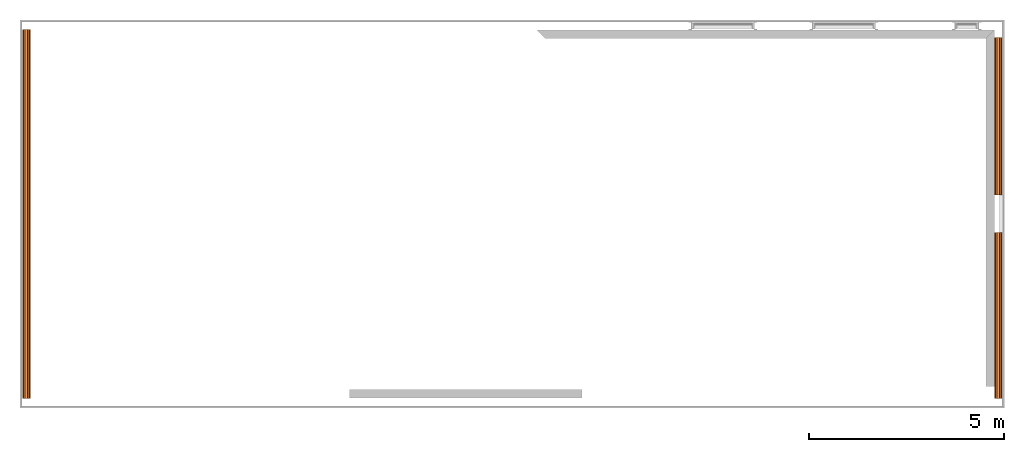
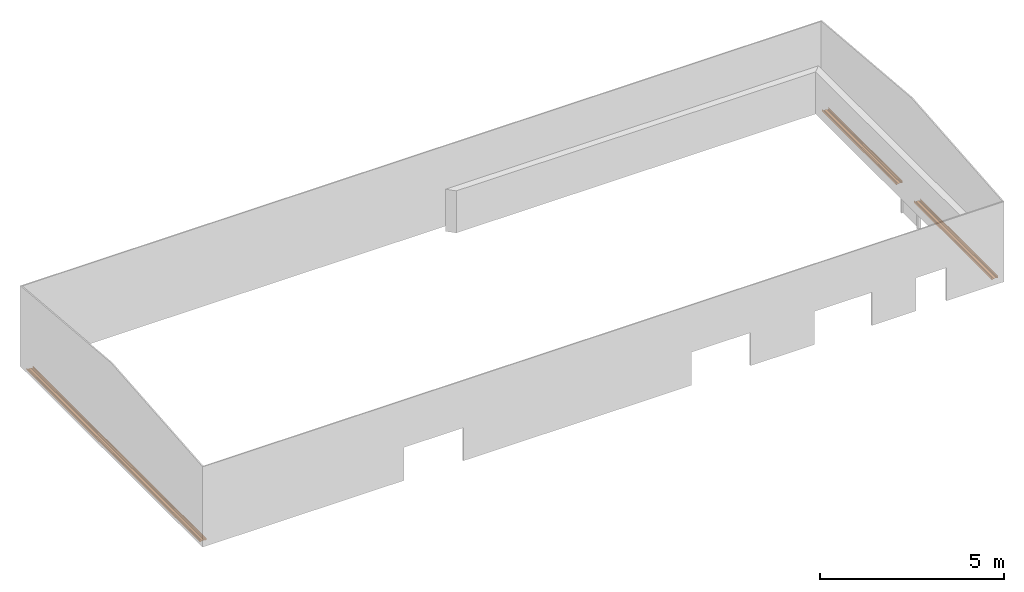
# One storey, part 4 of 4: 3 proxies.
"""IFC2X3 building model written with IfcOpenShell, lengths in millimetres."""

import ifcopenshell
import ifcopenshell.guid

model = None  # the IFC model being written
_history = None  # IfcOwnerHistory: only IFC2X3 demands one
_inside = {}  # id of a spatial element -> (the spatial element, [elements in it])
_under = {}  # id of a project, library or spatial element -> (it, [spatial elements below it])
_declared = {}  # id of a project -> (the project, [libraries it declares])
_typed = {}  # id of a type object -> (the type object, [elements of that type])
_made_of = {}  # id of a material, layer set ... -> (it, [elements and type objects made of it])


def new_model(schema):
    """Start an empty IFC model of exactly this schema.

    Asked for "IFC4X3", IfcOpenShell would pick the latest addendum, in which some entities
    have other attributes; the version numbers below select the first issue.
    IFC2X3 requires an IfcOwnerHistory on every rooted entity: one is made here for all.
    """
    global model, _history
    if schema == "IFC4X3":
        model = ifcopenshell.file(schema_version=(4, 3, 0, 0))
    else:
        model = ifcopenshell.file(schema=schema)
    _inside.clear()
    _under.clear()
    _declared.clear()
    _typed.clear()
    _made_of.clear()
    _history = None
    if model.schema == "IFC2X3":
        org = make("IfcOrganization", Name="unknown")
        user = make(
            "IfcPersonAndOrganization",
            ThePerson=make("IfcPerson", FamilyName="unknown"),
            TheOrganization=org,
        )
        app = make(
            "IfcApplication",
            ApplicationDeveloper=org,
            Version="unknown",
            ApplicationFullName="unknown",
            ApplicationIdentifier="unknown",
        )
        _history = make(
            "IfcOwnerHistory",
            OwningUser=user,
            OwningApplication=app,
            ChangeAction="ADDED",
            CreationDate=0,
        )
    return model


def make(cls, **values):
    """One entity of the class cls with the attributes given. An attribute that is None is left unset."""
    return model.create_entity(
        cls, **{name: value for name, value in values.items() if value is not None}
    )


def entity(cls, *values):
    """Any entity or typed value of the class cls, its attributes in the order of the schema. None: left unset."""
    e = model.create_entity(cls)
    for i, value in enumerate(values):
        if value is not None:
            e[i] = value
    return e


def rooted(cls, **values):
    """An entity with a GlobalId (a new one), such as an element, a storey or a relation."""
    return make(cls, GlobalId=ifcopenshell.guid.new(), OwnerHistory=_history, **values)


def si_unit(unit_type, name, prefix=None):
    """IfcSIUnit, for example si_unit("LENGTHUNIT", "METRE", prefix="MILLI")."""
    return make("IfcSIUnit", UnitType=unit_type, Prefix=prefix, Name=name)


def converted_unit(unit_type, name, factor, base, dimensions=None, offset=None):
    """IfcConversionBasedUnit, such as the inch: factor (a typed value) times the base unit."""
    return make(
        "IfcConversionBasedUnit"
        if offset is None
        else "IfcConversionBasedUnitWithOffset",
        ConversionOffset=offset,
        Dimensions=None
        if dimensions is None
        else entity("IfcDimensionalExponents", *dimensions),
        UnitType=unit_type,
        Name=name,
        ConversionFactor=make(
            "IfcMeasureWithUnit", ValueComponent=factor, UnitComponent=base
        ),
    )


def money_unit(currency):
    """IfcMonetaryUnit."""
    return make("IfcMonetaryUnit", Currency=currency)


def assignment(units):
    """IfcUnitAssignment: the units of a project."""
    return None if units is None else make("IfcUnitAssignment", Units=units)


def point(xyz):
    """IfcCartesianPoint."""
    return None if xyz is None else make("IfcCartesianPoint", Coordinates=xyz)


def direction(xyz):
    """IfcDirection."""
    return None if xyz is None else make("IfcDirection", DirectionRatios=xyz)


def frame(location, z_axis=None, x_axis=None):
    """IfcAxis2Placement3D, a coordinate frame: its origin and axes. An axis left out is left unset."""
    return make(
        "IfcAxis2Placement3D",
        Location=point(location),
        Axis=direction(z_axis),
        RefDirection=direction(x_axis),
    )


def origin_with_axes():
    """The frame at (0, 0, 0) with the z axis (0, 0, 1) and the x axis (1, 0, 0) written out."""
    return frame((0.0, 0.0, 0.0), z_axis=(0.0, 0.0, 1.0), x_axis=(1.0, 0.0, 0.0))


def place(relative_to, where):
    """IfcLocalPlacement: puts the frame where relative to a parent placement (None: the world)."""
    return make(
        "IfcLocalPlacement", PlacementRelTo=relative_to, RelativePlacement=where
    )


def context(
    kind, dimensions, precision=None, world=None, true_north=None, identifier=None
):
    """IfcGeometricRepresentationContext, for example the 3D "Model" context."""
    return make(
        "IfcGeometricRepresentationContext",
        ContextIdentifier=identifier,
        ContextType=kind,
        CoordinateSpaceDimension=dimensions,
        Precision=precision,
        WorldCoordinateSystem=world,
        TrueNorth=true_north,
    )


def subcontext(parent, identifier, kind, view, scale=None):
    """IfcGeometricRepresentationSubContext, for example "Body" below "Model"."""
    return make(
        "IfcGeometricRepresentationSubContext",
        ContextIdentifier=identifier,
        ContextType=kind,
        ParentContext=parent,
        TargetScale=scale,
        TargetView=view,
    )


def project(units=None, contexts=None):
    """IfcProject with its units and contexts."""
    return rooted(
        "IfcProject",
        Name="project",
        RepresentationContexts=contexts,
        UnitsInContext=assignment(units),
    )


def spatial(cls, under=None, at=None, **own):
    """A site, building, storey or space (cls), placed at a placement, below another one or the project."""
    s = rooted(cls, ObjectPlacement=at, **own)
    if under is not None:
        _under.setdefault(under.id(), (under, []))[1].append(s)
    return s


def faces_of(points, faces, orient=None, outer=None):
    """IfcFace entities. A face is a list of loops; a loop is a list of indices into points, from 0.

    orient and outer hold one flag for each loop. By default every Orientation is true, the
    first loop of a face is its IfcFaceOuterBound and the others are IfcFaceBound.
    """
    made = []
    for i, loops in enumerate(faces):
        bounds = []
        for j, loop in enumerate(loops):
            is_outer = j == 0 if outer is None else outer[i][j]
            bounds.append(
                make(
                    "IfcFaceOuterBound" if is_outer else "IfcFaceBound",
                    Bound=make("IfcPolyLoop", Polygon=[points[k] for k in loop]),
                    Orientation=True if orient is None else orient[i][j],
                )
            )
        made.append(make("IfcFace", Bounds=bounds))
    return made


def faceted_brep(points, faces, orient=None, outer=None, voids=None):
    """IfcFacetedBrep: a solid bounded by flat faces; with voids (closed shells), ...WithVoids."""
    shared = [point(p) for p in points]
    hull = make("IfcClosedShell", CfsFaces=faces_of(shared, faces, orient, outer))
    if voids is None:
        return make("IfcFacetedBrep", Outer=hull)
    return make(
        "IfcFacetedBrepWithVoids",
        Outer=hull,
        Voids=[
            make(cls, CfsFaces=faces_of(shared, fs, o, b)) for cls, fs, o, b in voids
        ],
    )


def shape(context_of_items, identifier, shape_type, items):
    """IfcShapeRepresentation: the items that make up one representation, for example the "Body"."""
    return make(
        "IfcShapeRepresentation",
        ContextOfItems=context_of_items,
        RepresentationIdentifier=identifier,
        RepresentationType=shape_type,
        Items=items,
    )


def material(Name=None, Category=None):
    """IfcMaterial."""
    return make("IfcMaterial", Name=Name, Category=Category)


def made_of(thing, what):
    """Note that an element or type object is made of a material, layer set ...; save() writes the relation."""
    if what is not None:
        _made_of.setdefault(what.id(), (what, []))[1].append(thing)
    return thing


def type_object(cls, material=None, **own):
    """A type object (cls), such as IfcWallType, which elements share."""
    return made_of(rooted(cls, **own), material)


def element(
    cls,
    number,
    at=None,
    inside=None,
    cuts=None,
    type_object=None,
    material=None,
    context=None,
    identifier="Body",
    shape_type=None,
    held_by="IfcProductDefinitionShape",
    body=None,
    shapes=None,
    **own,
):
    """One element of the class cls, such as IfcWall. Its Tag is "e" and its number.

    at: its placement. inside: the storey or other place that contains it. cuts: it is an
    opening in that element (IfcRelVoidsElement). A single representation is given by context,
    identifier, shape_type and body (its items); several are given by shapes. held_by: the class
    of the entity that holds the representations. save() writes the other relations.
    """
    e = rooted(cls, Tag="e%d" % number, ObjectPlacement=at, **own)
    if body is not None:
        shapes = [shape(context, identifier, shape_type, body)]
    if shapes is not None:
        e.Representation = make(held_by, Representations=shapes)
    if inside is not None:
        _inside.setdefault(inside.id(), (inside, []))[1].append(e)
    if cuts is not None:
        rooted(
            "IfcRelVoidsElement", RelatingBuildingElement=cuts, RelatedOpeningElement=e
        )
    if type_object is not None:
        _typed.setdefault(type_object.id(), (type_object, []))[1].append(e)
    return made_of(e, material)


def aggregate(whole, parts):
    """IfcRelAggregates: a whole, such as a stair, and the parts it consists of."""
    return rooted("IfcRelAggregates", RelatingObject=whole, RelatedObjects=parts)


def save(model, path):
    """Write the relations noted so far, then the file.

    IfcRelAggregates (storeys below a building ...), IfcRelContainedInSpatialStructure (elements
    in a storey), IfcRelDefinesByType, IfcRelAssociatesMaterial and IfcRelDeclares: one each for
    every whole, place, type object, material and project.
    """
    for whole, parts in _under.values():
        aggregate(whole, parts)
    for where, things in _inside.values():
        rooted(
            "IfcRelContainedInSpatialStructure",
            RelatedElements=things,
            RelatingStructure=where,
        )
    for kind, things in _typed.values():
        rooted("IfcRelDefinesByType", RelatedObjects=things, RelatingType=kind)
    for what, things in _made_of.values():
        rooted("IfcRelAssociatesMaterial", RelatedObjects=things, RelatingMaterial=what)
    for by, libraries in _declared.values():
        rooted("IfcRelDeclares", RelatingContext=by, RelatedDefinitions=libraries)
    model.write(path)


model = new_model("IFC2X3")

# Units and contexts
model_context = context("Model", 3, precision=1e-05, world=origin_with_axes(), true_north=direction((0.0, 1.0)))
body_context = subcontext(model_context, "Body", "Model", "MODEL_VIEW")
ifc_project = project(units=[si_unit("LENGTHUNIT", "METRE", prefix="MILLI"), si_unit("AREAUNIT", "SQUARE_METRE"), si_unit("VOLUMEUNIT", "CUBIC_METRE"), converted_unit("PLANEANGLEUNIT", "DEGREE", entity("IfcPlaneAngleMeasure", 0.0174532925199), si_unit("PLANEANGLEUNIT", "RADIAN"), dimensions=[0, 0, 0, 0, 0, 0, 0]), si_unit("SOLIDANGLEUNIT", "STERADIAN"), money_unit("USD"), converted_unit("TIMEUNIT", "Year", entity("IfcTimeMeasure", 31556926.0), si_unit("TIMEUNIT", "SECOND"), dimensions=[0, 0, 0, 0, 0, 0, 0]), si_unit("MASSUNIT", "GRAM"), si_unit("THERMODYNAMICTEMPERATUREUNIT", "DEGREE_CELSIUS"), si_unit("LUMINOUSINTENSITYUNIT", "LUMEN")], contexts=[model_context])

# Site, building, storey
site_placement = place(None, origin_with_axes())
site = spatial("IfcSite", under=ifc_project, at=site_placement, CompositionType="ELEMENT")
building_placement = place(site_placement, origin_with_axes())
building = spatial("IfcBuilding", under=site, at=building_placement, CompositionType="ELEMENT")
storey_placement = place(building_placement, frame((0.0, 0.0, 71700.0), z_axis=(0.0, 0.0, 1.0), x_axis=(1.0, 0.0, 0.0)))
storey = spatial("IfcBuildingStorey", under=building, at=storey_placement, CompositionType="ELEMENT", Elevation=71700.0)

# Proxies
ifc_material_1 = material(Name="Metal - Steel - Light Gauge")
building_element_proxy_type_1 = type_object("IfcBuildingElementProxyType", Name="M", PredefinedType="USERDEFINED")
proxy_1_placement = place(storey_placement, frame((16615.5295383, 1237.47930537, 0.0), z_axis=(0.0, 0.0, 1.0), x_axis=(0.0, -1.0, 0.0)))
element("IfcBuildingElementProxy", 1, at=proxy_1_placement, inside=storey, type_object=building_element_proxy_type_1, material=ifc_material_1, Name="Light Gauge-Kingspan Rails:M", ObjectType="M", context=body_context, shape_type="Brep", body=[
    faceted_brep([(-1860.0014251, 70.5, 0.0), (-1860.0014251, 99.3, 0.0), (2385.5, 99.3, 0.0), (2385.5, 70.5, 0.0), (-1860.0014251, 32.5, 20.0), (-1860.0014251, -32.5, 20.0), (-1860.0014251, -70.5, 0.0), (-1860.0014251, -99.3, 0.0), (-1860.0014251, -100.524586984, 0.24358549596), (-1860.0014251, -101.5627417, 0.9372583002), (-1860.0014251, -102.256414504, 1.97541301643), (-1860.0014251, -102.5, 3.2), (-1860.0014251, -102.5, 61.8), (-1860.0014251, -102.256414504, 63.0245869836), (-1860.0014251, -101.5627417, 64.0627416998), (-1860.0014251, -100.524586984, 64.756414504), (-1860.0014251, -99.3, 65.0), (-1860.0014251, -91.7, 65.0), (-1860.0014251, -90.4754130164, 64.756414504), (-1860.0014251, -89.4372583002, 64.0627416998), (-1860.0014251, -88.743585496, 63.0245869836), (-1860.0014251, -88.5, 61.8), (-1860.0014251, -88.5, 53.0), (-1860.0014251, -90.1, 53.0), (-1860.0014251, -90.1, 61.8), (-1860.0014251, -90.221792748, 62.4122934918), (-1860.0014251, -90.5686291501, 62.9313708499), (-1860.0014251, -91.0877065082, 63.278207252), (-1860.0014251, -91.7, 63.4), (-1860.0014251, -99.3, 63.4), (-1860.0014251, -99.9122934918, 63.278207252), (-1860.0014251, -100.43137085, 62.9313708499), (-1860.0014251, -100.778207252, 62.4122934918), (-1860.0014251, -100.9, 61.8), (-1860.0014251, -100.9, 3.2), (-1860.0014251, -100.778207252, 2.58770650822), (-1860.0014251, -100.43137085, 2.0686291501), (-1860.0014251, -99.9122934918, 1.72179274798), (-1860.0014251, -99.3, 1.6), (-1860.0014251, -70.8953456886, 1.6), (-1860.0014251, -32.8953456886, 21.6), (-1860.0014251, 32.8953456886, 21.6), (-1860.0014251, 70.8953456886, 1.6), (-1860.0014251, 99.3, 1.6), (-1860.0014251, 99.9122934918, 1.72179274798), (-1860.0014251, 100.43137085, 2.0686291501), (-1860.0014251, 100.778207252, 2.58770650822), (-1860.0014251, 100.9, 3.2), (-1860.0014251, 100.9, 61.8), (-1860.0014251, 100.778207252, 62.4122934918), (-1860.0014251, 100.43137085, 62.9313708499), (-1860.0014251, 99.9122934918, 63.278207252), (-1860.0014251, 99.3, 63.4), (-1860.0014251, 91.7, 63.4), (-1860.0014251, 91.0877065082, 63.278207252), (-1860.0014251, 90.5686291501, 62.9313708499), (-1860.0014251, 90.221792748, 62.4122934918), (-1860.0014251, 90.1, 61.8), (-1860.0014251, 90.1, 53.0), (-1860.0014251, 88.5, 53.0), (-1860.0014251, 88.5, 61.8), (-1860.0014251, 88.743585496, 63.0245869836), (-1860.0014251, 89.4372583002, 64.0627416998), (-1860.0014251, 90.4754130164, 64.756414504), (-1860.0014251, 91.7, 65.0), (-1860.0014251, 99.3, 65.0), (-1860.0014251, 100.524586984, 64.756414504), (-1860.0014251, 101.5627417, 64.0627416998), (-1860.0014251, 102.256414504, 63.0245869836), (-1860.0014251, 102.5, 61.8), (-1860.0014251, 102.5, 3.2), (-1860.0014251, 102.256414504, 1.97541301643), (-1860.0014251, 101.5627417, 0.9372583002), (-1860.0014251, 100.524586984, 0.24358549596), (2385.5, 100.524586984, 0.24358549596), (2385.5, 101.5627417, 0.9372583002), (2385.5, 102.256414504, 1.97541301643), (2385.5, 102.5, 3.2), (2385.5, 102.5, 61.8), (2385.5, 102.256414504, 63.0245869836), (2385.5, 101.5627417, 64.0627416998), (2385.5, 100.524586984, 64.756414504), (2385.5, 99.3, 65.0), (2385.5, 91.7, 65.0), (2385.5, 90.4754130164, 64.756414504), (2385.5, 89.4372583002, 64.0627416998), (2385.5, 88.743585496, 63.0245869836), (2385.5, 88.5, 61.8), (2385.5, 88.5, 53.0), (2385.5, 90.1, 53.0), (2385.5, 90.1, 61.8), (2385.5, 90.221792748, 62.4122934918), (2385.5, 90.5686291501, 62.9313708499), (2385.5, 91.0877065082, 63.278207252), (2385.5, 91.7, 63.4), (2385.5, 99.3, 63.4), (2385.5, 99.9122934918, 63.278207252), (2385.5, 100.43137085, 62.9313708499), (2385.5, 100.778207252, 62.4122934918), (2385.5, 100.9, 61.8), (2385.5, 100.9, 3.2), (2385.5, 100.778207252, 2.58770650822), (2385.5, 100.43137085, 2.0686291501), (2385.5, 99.9122934918, 1.72179274798), (2385.5, 99.3, 1.6), (2385.5, 70.8953456886, 1.6), (2385.5, 32.8953456886, 21.6), (2385.5, -32.8953456886, 21.6), (2385.5, -70.8953456886, 1.6), (2385.5, -99.3, 1.6), (2385.5, -99.9122934918, 1.72179274798), (2385.5, -100.43137085, 2.0686291501), (2385.5, -100.778207252, 2.58770650822), (2385.5, -100.9, 3.2), (2385.5, -100.9, 61.8), (2385.5, -100.778207252, 62.4122934918), (2385.5, -100.43137085, 62.9313708499), (2385.5, -99.9122934918, 63.278207252), (2385.5, -99.3, 63.4), (2385.5, -91.7, 63.4), (2385.5, -91.0877065082, 63.278207252), (2385.5, -90.5686291501, 62.9313708499), (2385.5, -90.221792748, 62.4122934918), (2385.5, -90.1, 61.8), (2385.5, -90.1, 53.0), (2385.5, -88.5, 53.0), (2385.5, -88.5, 61.8), (2385.5, -88.743585496, 63.0245869836), (2385.5, -89.4372583002, 64.0627416998), (2385.5, -90.4754130164, 64.756414504), (2385.5, -91.7, 65.0), (2385.5, -99.3, 65.0), (2385.5, -100.524586984, 64.756414504), (2385.5, -101.5627417, 64.0627416998), (2385.5, -102.256414504, 63.0245869836), (2385.5, -102.5, 61.8), (2385.5, -102.5, 3.2), (2385.5, -102.256414504, 1.97541301643), (2385.5, -101.5627417, 0.9372583002), (2385.5, -100.524586984, 0.24358549596), (2385.5, -99.3, 0.0), (2385.5, -70.5, 0.0), (2385.5, -32.5, 20.0), (2385.5, 32.5, 20.0)], [[[0, 1, 2, 3]], [[0, 4, 5, 6, 7, 8, 9, 10, 11, 12, 13, 14, 15, 16, 17, 18, 19, 20, 21, 22, 23, 24, 25, 26, 27, 28, 29, 30, 31, 32, 33, 34, 35, 36, 37, 38, 39, 40, 41, 42, 43, 44, 45, 46, 47, 48, 49, 50, 51, 52, 53, 54, 55, 56, 57, 58, 59, 60, 61, 62, 63, 64, 65, 66, 67, 68, 69, 70, 71, 72, 73, 1]], [[1, 73, 74, 2]], [[3, 2, 74, 75, 76, 77, 78, 79, 80, 81, 82, 83, 84, 85, 86, 87, 88, 89, 90, 91, 92, 93, 94, 95, 96, 97, 98, 99, 100, 101, 102, 103, 104, 105, 106, 107, 108, 109, 110, 111, 112, 113, 114, 115, 116, 117, 118, 119, 120, 121, 122, 123, 124, 125, 126, 127, 128, 129, 130, 131, 132, 133, 134, 135, 136, 137, 138, 139, 140, 141, 142, 143]], [[4, 0, 3, 143]], [[5, 4, 143, 142]], [[6, 5, 142, 141]], [[7, 6, 141, 140]], [[8, 7, 140, 139]], [[9, 8, 139, 138]], [[10, 9, 138, 137]], [[11, 10, 137, 136]], [[12, 11, 136, 135]], [[13, 12, 135, 134]], [[14, 13, 134, 133]], [[15, 14, 133, 132]], [[16, 15, 132, 131]], [[17, 16, 131, 130]], [[18, 17, 130, 129]], [[19, 18, 129, 128]], [[20, 19, 128, 127]], [[21, 20, 127, 126]], [[22, 21, 126, 125]], [[23, 22, 125, 124]], [[24, 23, 124, 123]], [[25, 24, 123, 122]], [[26, 25, 122, 121]], [[27, 26, 121, 120]], [[28, 27, 120, 119]], [[29, 28, 119, 118]], [[30, 29, 118, 117]], [[31, 30, 117, 116]], [[32, 31, 116, 115]], [[33, 32, 115, 114]], [[34, 33, 114, 113]], [[35, 34, 113, 112]], [[36, 35, 112, 111]], [[37, 36, 111, 110]], [[38, 37, 110, 109]], [[39, 38, 109, 108]], [[40, 39, 108, 107]], [[41, 40, 107, 106]], [[42, 41, 106, 105]], [[43, 42, 105, 104]], [[44, 43, 104, 103]], [[45, 44, 103, 102]], [[46, 45, 102, 101]], [[47, 46, 101, 100]], [[48, 47, 100, 99]], [[49, 48, 99, 98]], [[50, 49, 98, 97]], [[51, 50, 97, 96]], [[52, 51, 96, 95]], [[53, 52, 95, 94]], [[54, 53, 94, 93]], [[55, 54, 93, 92]], [[56, 55, 92, 91]], [[57, 56, 91, 90]], [[58, 57, 90, 89]], [[59, 58, 89, 88]], [[60, 59, 88, 87]], [[61, 60, 87, 86]], [[62, 61, 86, 85]], [[63, 62, 85, 84]], [[64, 63, 84, 83]], [[65, 64, 83, 82]], [[66, 65, 82, 81]], [[67, 66, 81, 80]], [[68, 67, 80, 79]], [[69, 68, 79, 78]], [[70, 69, 78, 77]], [[71, 70, 77, 76]], [[72, 71, 76, 75]], [[73, 72, 75, 74]]]),
])
ifc_material_2 = material(Name="Metal - Steel 43-275")
building_element_proxy_type_2 = type_object("IfcBuildingElementProxyType", Name="M", PredefinedType="USERDEFINED")
proxy_2_placement = place(storey_placement, frame((16615.5295383, 5944.98053801, 0.0), z_axis=(0.0, 0.0, 1.0), x_axis=(0.0, -1.0, 0.0)))
element("IfcBuildingElementProxy", 2, at=proxy_2_placement, inside=storey, type_object=building_element_proxy_type_2, material=ifc_material_2, Name="Light Gauge-Kingspan Rails:M", ObjectType="M", context=body_context, shape_type="Brep", body=[
    faceted_brep([(-2154.0, 70.5, 0.0), (-2154.0, 99.3, 0.0), (1887.0, 99.3, 0.0), (1887.0, 70.5, 0.0), (-2154.0, 32.5, 20.0), (-2154.0, -32.5, 20.0), (-2154.0, -70.5, 0.0), (-2154.0, -99.3, 0.0), (-2154.0, -100.524586984, 0.24358549596), (-2154.0, -101.5627417, 0.9372583002), (-2154.0, -102.256414504, 1.97541301643), (-2154.0, -102.5, 3.2), (-2154.0, -102.5, 61.8), (-2154.0, -102.256414504, 63.0245869836), (-2154.0, -101.5627417, 64.0627416998), (-2154.0, -100.524586984, 64.756414504), (-2154.0, -99.3, 65.0), (-2154.0, -91.7, 65.0), (-2154.0, -90.4754130164, 64.756414504), (-2154.0, -89.4372583002, 64.0627416998), (-2154.0, -88.743585496, 63.0245869836), (-2154.0, -88.5, 61.8), (-2154.0, -88.5, 53.0), (-2154.0, -90.1, 53.0), (-2154.0, -90.1, 61.8), (-2154.0, -90.221792748, 62.4122934918), (-2154.0, -90.5686291501, 62.9313708499), (-2154.0, -91.0877065082, 63.278207252), (-2154.0, -91.7, 63.4), (-2154.0, -99.3, 63.4), (-2154.0, -99.9122934918, 63.278207252), (-2154.0, -100.43137085, 62.9313708499), (-2154.0, -100.778207252, 62.4122934918), (-2154.0, -100.9, 61.8), (-2154.0, -100.9, 3.2), (-2154.0, -100.778207252, 2.58770650822), (-2154.0, -100.43137085, 2.0686291501), (-2154.0, -99.9122934918, 1.72179274798), (-2154.0, -99.3, 1.6), (-2154.0, -70.8953456886, 1.6), (-2154.0, -32.8953456886, 21.6), (-2154.0, 32.8953456886, 21.6), (-2154.0, 70.8953456886, 1.6), (-2154.0, 99.3, 1.6), (-2154.0, 99.9122934918, 1.72179274798), (-2154.0, 100.43137085, 2.0686291501), (-2154.0, 100.778207252, 2.58770650822), (-2154.0, 100.9, 3.2), (-2154.0, 100.9, 61.8), (-2154.0, 100.778207252, 62.4122934918), (-2154.0, 100.43137085, 62.9313708499), (-2154.0, 99.9122934918, 63.278207252), (-2154.0, 99.3, 63.4), (-2154.0, 91.7, 63.4), (-2154.0, 91.0877065082, 63.278207252), (-2154.0, 90.5686291501, 62.9313708499), (-2154.0, 90.221792748, 62.4122934918), (-2154.0, 90.1, 61.8), (-2154.0, 90.1, 53.0), (-2154.0, 88.5, 53.0), (-2154.0, 88.5, 61.8), (-2154.0, 88.743585496, 63.0245869836), (-2154.0, 89.4372583002, 64.0627416998), (-2154.0, 90.4754130164, 64.756414504), (-2154.0, 91.7, 65.0), (-2154.0, 99.3, 65.0), (-2154.0, 100.524586984, 64.756414504), (-2154.0, 101.5627417, 64.0627416998), (-2154.0, 102.256414504, 63.0245869836), (-2154.0, 102.5, 61.8), (-2154.0, 102.5, 3.2), (-2154.0, 102.256414504, 1.97541301643), (-2154.0, 101.5627417, 0.9372583002), (-2154.0, 100.524586984, 0.24358549596), (1887.0, 100.524586984, 0.24358549596), (1887.0, 101.5627417, 0.9372583002), (1887.0, 102.256414504, 1.97541301643), (1887.0, 102.5, 3.2), (1887.0, 102.5, 61.8), (1887.0, 102.256414504, 63.0245869836), (1887.0, 101.5627417, 64.0627416998), (1887.0, 100.524586984, 64.756414504), (1887.0, 99.3, 65.0), (1887.0, 91.7, 65.0), (1887.0, 90.4754130164, 64.756414504), (1887.0, 89.4372583002, 64.0627416998), (1887.0, 88.743585496, 63.0245869836), (1887.0, 88.5, 61.8), (1887.0, 88.5, 53.0), (1887.0, 90.1, 53.0), (1887.0, 90.1, 61.8), (1887.0, 90.221792748, 62.4122934918), (1887.0, 90.5686291501, 62.9313708499), (1887.0, 91.0877065082, 63.278207252), (1887.0, 91.7, 63.4), (1887.0, 99.3, 63.4), (1887.0, 99.9122934918, 63.278207252), (1887.0, 100.43137085, 62.9313708499), (1887.0, 100.778207252, 62.4122934918), (1887.0, 100.9, 61.8), (1887.0, 100.9, 3.2), (1887.0, 100.778207252, 2.58770650822), (1887.0, 100.43137085, 2.0686291501), (1887.0, 99.9122934918, 1.72179274798), (1887.0, 99.3, 1.6), (1887.0, 70.8953456886, 1.6), (1887.0, 32.8953456886, 21.6), (1887.0, -32.8953456886, 21.6), (1887.0, -70.8953456886, 1.6), (1887.0, -99.3, 1.6), (1887.0, -99.9122934918, 1.72179274798), (1887.0, -100.43137085, 2.0686291501), (1887.0, -100.778207252, 2.58770650822), (1887.0, -100.9, 3.2), (1887.0, -100.9, 61.8), (1887.0, -100.778207252, 62.4122934918), (1887.0, -100.43137085, 62.9313708499), (1887.0, -99.9122934918, 63.278207252), (1887.0, -99.3, 63.4), (1887.0, -91.7, 63.4), (1887.0, -91.0877065082, 63.278207252), (1887.0, -90.5686291501, 62.9313708499), (1887.0, -90.221792748, 62.4122934918), (1887.0, -90.1, 61.8), (1887.0, -90.1, 53.0), (1887.0, -88.5, 53.0), (1887.0, -88.5, 61.8), (1887.0, -88.743585496, 63.0245869836), (1887.0, -89.4372583002, 64.0627416998), (1887.0, -90.4754130164, 64.756414504), (1887.0, -91.7, 65.0), (1887.0, -99.3, 65.0), (1887.0, -100.524586984, 64.756414504), (1887.0, -101.5627417, 64.0627416998), (1887.0, -102.256414504, 63.0245869836), (1887.0, -102.5, 61.8), (1887.0, -102.5, 3.2), (1887.0, -102.256414504, 1.97541301643), (1887.0, -101.5627417, 0.9372583002), (1887.0, -100.524586984, 0.24358549596), (1887.0, -99.3, 0.0), (1887.0, -70.5, 0.0), (1887.0, -32.5, 20.0), (1887.0, 32.5, 20.0)], [[[0, 1, 2, 3]], [[0, 4, 5, 6, 7, 8, 9, 10, 11, 12, 13, 14, 15, 16, 17, 18, 19, 20, 21, 22, 23, 24, 25, 26, 27, 28, 29, 30, 31, 32, 33, 34, 35, 36, 37, 38, 39, 40, 41, 42, 43, 44, 45, 46, 47, 48, 49, 50, 51, 52, 53, 54, 55, 56, 57, 58, 59, 60, 61, 62, 63, 64, 65, 66, 67, 68, 69, 70, 71, 72, 73, 1]], [[1, 73, 74, 2]], [[3, 2, 74, 75, 76, 77, 78, 79, 80, 81, 82, 83, 84, 85, 86, 87, 88, 89, 90, 91, 92, 93, 94, 95, 96, 97, 98, 99, 100, 101, 102, 103, 104, 105, 106, 107, 108, 109, 110, 111, 112, 113, 114, 115, 116, 117, 118, 119, 120, 121, 122, 123, 124, 125, 126, 127, 128, 129, 130, 131, 132, 133, 134, 135, 136, 137, 138, 139, 140, 141, 142, 143]], [[4, 0, 3, 143]], [[5, 4, 143, 142]], [[6, 5, 142, 141]], [[7, 6, 141, 140]], [[8, 7, 140, 139]], [[9, 8, 139, 138]], [[10, 9, 138, 137]], [[11, 10, 137, 136]], [[12, 11, 136, 135]], [[13, 12, 135, 134]], [[14, 13, 134, 133]], [[15, 14, 133, 132]], [[16, 15, 132, 131]], [[17, 16, 131, 130]], [[18, 17, 130, 129]], [[19, 18, 129, 128]], [[20, 19, 128, 127]], [[21, 20, 127, 126]], [[22, 21, 126, 125]], [[23, 22, 125, 124]], [[24, 23, 124, 123]], [[25, 24, 123, 122]], [[26, 25, 122, 121]], [[27, 26, 121, 120]], [[28, 27, 120, 119]], [[29, 28, 119, 118]], [[30, 29, 118, 117]], [[31, 30, 117, 116]], [[32, 31, 116, 115]], [[33, 32, 115, 114]], [[34, 33, 114, 113]], [[35, 34, 113, 112]], [[36, 35, 112, 111]], [[37, 36, 111, 110]], [[38, 37, 110, 109]], [[39, 38, 109, 108]], [[40, 39, 108, 107]], [[41, 40, 107, 106]], [[42, 41, 106, 105]], [[43, 42, 105, 104]], [[44, 43, 104, 103]], [[45, 44, 103, 102]], [[46, 45, 102, 101]], [[47, 46, 101, 100]], [[48, 47, 100, 99]], [[49, 48, 99, 98]], [[50, 49, 98, 97]], [[51, 50, 97, 96]], [[52, 51, 96, 95]], [[53, 52, 95, 94]], [[54, 53, 94, 93]], [[55, 54, 93, 92]], [[56, 55, 92, 91]], [[57, 56, 91, 90]], [[58, 57, 90, 89]], [[59, 58, 89, 88]], [[60, 59, 88, 87]], [[61, 60, 87, 86]], [[62, 61, 86, 85]], [[63, 62, 85, 84]], [[64, 63, 84, 83]], [[65, 64, 83, 82]], [[66, 65, 82, 81]], [[67, 66, 81, 80]], [[68, 67, 80, 79]], [[69, 68, 79, 78]], [[70, 69, 78, 77]], [[71, 70, 77, 76]], [[72, 71, 76, 75]], [[73, 72, 75, 74]]]),
])
building_element_proxy_type_3 = type_object("IfcBuildingElementProxyType", Name="M", PredefinedType="USERDEFINED")
proxy_3_placement = place(storey_placement, frame((-8295.42046281, 3597.47992169, 0.0), z_axis=(0.0, 0.0, 1.0), x_axis=(0.0, -1.0, 0.0)))
element("IfcBuildingElementProxy", 3, at=proxy_3_placement, inside=storey, type_object=building_element_proxy_type_3, material=ifc_material_2, Name="Light Gauge-Kingspan Rails:M", ObjectType="M", context=body_context, shape_type="Brep", body=[
    faceted_brep([(4745.5, -70.5, 0.0), (4745.5, -99.3, 0.0), (-4704.79875225, -99.3, 0.0), (-4704.79875225, -70.5, 0.0), (4745.5, -32.5, 20.0), (4745.5, 32.5, 20.0), (4745.5, 70.5, 0.0), (4745.5, 99.3, 0.0), (4745.5, 100.524586984, 0.24358549596), (4745.5, 101.5627417, 0.9372583002), (4745.5, 102.256414504, 1.97541301643), (4745.5, 102.5, 3.2), (4745.5, 102.5, 61.8), (4745.5, 102.256414504, 63.0245869836), (4745.5, 101.5627417, 64.0627416998), (4745.5, 100.524586984, 64.756414504), (4745.5, 99.3, 65.0), (4745.5, 91.7, 65.0), (4745.5, 90.4754130164, 64.756414504), (4745.5, 89.4372583002, 64.0627416998), (4745.5, 88.743585496, 63.0245869836), (4745.5, 88.5, 61.8), (4745.5, 88.5, 53.0), (4745.5, 90.1, 53.0), (4745.5, 90.1, 61.8), (4745.5, 90.221792748, 62.4122934918), (4745.5, 90.5686291501, 62.9313708499), (4745.5, 91.0877065082, 63.278207252), (4745.5, 91.7, 63.4), (4745.5, 99.3, 63.4), (4745.5, 99.9122934918, 63.278207252), (4745.5, 100.43137085, 62.9313708499), (4745.5, 100.778207252, 62.4122934918), (4745.5, 100.9, 61.8), (4745.5, 100.9, 3.19999999999), (4745.5, 100.778207252, 2.58770650821), (4745.5, 100.43137085, 2.0686291501), (4745.5, 99.9122934918, 1.72179274798), (4745.5, 99.3, 1.6), (4745.5, 70.8953456886, 1.6), (4745.5, 32.8953456886, 21.6), (4745.5, -32.8953456886, 21.6), (4745.5, -70.8953456886, 1.6), (4745.5, -99.3, 1.6), (4745.5, -99.9122934918, 1.72179274798), (4745.5, -100.43137085, 2.0686291501), (4745.5, -100.778207252, 2.58770650821), (4745.5, -100.9, 3.19999999999), (4745.5, -100.9, 61.8), (4745.5, -100.778207252, 62.4122934918), (4745.5, -100.43137085, 62.9313708499), (4745.5, -99.9122934918, 63.278207252), (4745.5, -99.3, 63.4), (4745.5, -91.7, 63.4), (4745.5, -91.0877065082, 63.278207252), (4745.5, -90.5686291501, 62.9313708499), (4745.5, -90.221792748, 62.4122934918), (4745.5, -90.1, 61.8), (4745.5, -90.1, 53.0), (4745.5, -88.5, 53.0), (4745.5, -88.5, 61.8), (4745.5, -88.743585496, 63.0245869836), (4745.5, -89.4372583002, 64.0627416998), (4745.5, -90.4754130164, 64.756414504), (4745.5, -91.7, 65.0), (4745.5, -99.3, 65.0), (4745.5, -100.524586984, 64.756414504), (4745.5, -101.5627417, 64.0627416998), (4745.5, -102.256414504, 63.0245869836), (4745.5, -102.5, 61.8), (4745.5, -102.5, 3.19999999999), (4745.5, -102.256414504, 1.97541301643), (4745.5, -101.5627417, 0.9372583002), (4745.5, -100.524586984, 0.24358549596), (-4704.79875225, -100.524586984, 0.24358549596), (-4704.79875225, -101.5627417, 0.9372583002), (-4704.79875225, -102.256414504, 1.97541301643), (-4704.79875225, -102.5, 3.19999999999), (-4704.79875225, -102.5, 61.8), (-4704.79875225, -102.256414504, 63.0245869836), (-4704.79875225, -101.5627417, 64.0627416998), (-4704.79875225, -100.524586984, 64.756414504), (-4704.79875225, -99.3, 65.0), (-4704.79875225, -91.7, 65.0), (-4704.79875225, -90.4754130164, 64.756414504), (-4704.79875225, -89.4372583002, 64.0627416998), (-4704.79875225, -88.743585496, 63.0245869836), (-4704.79875225, -88.5, 61.8), (-4704.79875225, -88.5, 53.0), (-4704.79875225, -90.1, 53.0), (-4704.79875225, -90.1, 61.8), (-4704.79875225, -90.221792748, 62.4122934918), (-4704.79875225, -90.5686291501, 62.9313708499), (-4704.79875225, -91.0877065082, 63.278207252), (-4704.79875225, -91.7, 63.4), (-4704.79875225, -99.3, 63.4), (-4704.79875225, -99.9122934918, 63.278207252), (-4704.79875225, -100.43137085, 62.9313708499), (-4704.79875225, -100.778207252, 62.4122934918), (-4704.79875225, -100.9, 61.8), (-4704.79875225, -100.9, 3.19999999999), (-4704.79875225, -100.778207252, 2.58770650821), (-4704.79875225, -100.43137085, 2.0686291501), (-4704.79875225, -99.9122934918, 1.72179274798), (-4704.79875225, -99.3, 1.6), (-4704.79875225, -70.8953456886, 1.6), (-4704.79875225, -32.8953456886, 21.6), (-4704.79875225, 32.8953456886, 21.6), (-4704.79875225, 70.8953456886, 1.6), (-4704.79875225, 99.3, 1.6), (-4704.79875225, 99.9122934918, 1.72179274798), (-4704.79875225, 100.43137085, 2.0686291501), (-4704.79875225, 100.778207252, 2.58770650821), (-4704.79875225, 100.9, 3.19999999999), (-4704.79875225, 100.9, 61.8), (-4704.79875225, 100.778207252, 62.4122934918), (-4704.79875225, 100.43137085, 62.9313708499), (-4704.79875225, 99.9122934918, 63.278207252), (-4704.79875225, 99.3, 63.4), (-4704.79875225, 91.7, 63.4), (-4704.79875225, 91.0877065082, 63.278207252), (-4704.79875225, 90.5686291501, 62.9313708499), (-4704.79875225, 90.221792748, 62.4122934918), (-4704.79875225, 90.1, 61.8), (-4704.79875225, 90.1, 53.0), (-4704.79875225, 88.5, 53.0), (-4704.79875225, 88.5, 61.8), (-4704.79875225, 88.743585496, 63.0245869836), (-4704.79875225, 89.4372583002, 64.0627416998), (-4704.79875225, 90.4754130164, 64.756414504), (-4704.79875225, 91.7, 65.0), (-4704.79875225, 99.3, 65.0), (-4704.79875225, 100.524586984, 64.756414504), (-4704.79875225, 101.5627417, 64.0627416998), (-4704.79875225, 102.256414504, 63.0245869836), (-4704.79875225, 102.5, 61.8), (-4704.79875225, 102.5, 3.2), (-4704.79875225, 102.256414504, 1.97541301643), (-4704.79875225, 101.5627417, 0.9372583002), (-4704.79875225, 100.524586984, 0.24358549596), (-4704.79875225, 99.3, 0.0), (-4704.79875225, 70.5, 0.0), (-4704.79875225, 32.5, 20.0), (-4704.79875225, -32.5, 20.0)], [[[0, 1, 2, 3]], [[0, 4, 5, 6, 7, 8, 9, 10, 11, 12, 13, 14, 15, 16, 17, 18, 19, 20, 21, 22, 23, 24, 25, 26, 27, 28, 29, 30, 31, 32, 33, 34, 35, 36, 37, 38, 39, 40, 41, 42, 43, 44, 45, 46, 47, 48, 49, 50, 51, 52, 53, 54, 55, 56, 57, 58, 59, 60, 61, 62, 63, 64, 65, 66, 67, 68, 69, 70, 71, 72, 73, 1]], [[1, 73, 74, 2]], [[3, 2, 74, 75, 76, 77, 78, 79, 80, 81, 82, 83, 84, 85, 86, 87, 88, 89, 90, 91, 92, 93, 94, 95, 96, 97, 98, 99, 100, 101, 102, 103, 104, 105, 106, 107, 108, 109, 110, 111, 112, 113, 114, 115, 116, 117, 118, 119, 120, 121, 122, 123, 124, 125, 126, 127, 128, 129, 130, 131, 132, 133, 134, 135, 136, 137, 138, 139, 140, 141, 142, 143]], [[4, 0, 3, 143]], [[5, 4, 143, 142]], [[6, 5, 142, 141]], [[7, 6, 141, 140]], [[8, 7, 140, 139]], [[9, 8, 139, 138]], [[10, 9, 138, 137]], [[11, 10, 137, 136]], [[12, 11, 136, 135]], [[13, 12, 135, 134]], [[14, 13, 134, 133]], [[15, 14, 133, 132]], [[16, 15, 132, 131]], [[17, 16, 131, 130]], [[18, 17, 130, 129]], [[19, 18, 129, 128]], [[20, 19, 128, 127]], [[21, 20, 127, 126]], [[22, 21, 126, 125]], [[23, 22, 125, 124]], [[24, 23, 124, 123]], [[25, 24, 123, 122]], [[26, 25, 122, 121]], [[27, 26, 121, 120]], [[28, 27, 120, 119]], [[29, 28, 119, 118]], [[30, 29, 118, 117]], [[31, 30, 117, 116]], [[32, 31, 116, 115]], [[33, 32, 115, 114]], [[34, 33, 114, 113]], [[35, 34, 113, 112]], [[36, 35, 112, 111]], [[37, 36, 111, 110]], [[38, 37, 110, 109]], [[39, 38, 109, 108]], [[40, 39, 108, 107]], [[41, 40, 107, 106]], [[42, 41, 106, 105]], [[43, 42, 105, 104]], [[44, 43, 104, 103]], [[45, 44, 103, 102]], [[46, 45, 102, 101]], [[47, 46, 101, 100]], [[48, 47, 100, 99]], [[49, 48, 99, 98]], [[50, 49, 98, 97]], [[51, 50, 97, 96]], [[52, 51, 96, 95]], [[53, 52, 95, 94]], [[54, 53, 94, 93]], [[55, 54, 93, 92]], [[56, 55, 92, 91]], [[57, 56, 91, 90]], [[58, 57, 90, 89]], [[59, 58, 89, 88]], [[60, 59, 88, 87]], [[61, 60, 87, 86]], [[62, 61, 86, 85]], [[63, 62, 85, 84]], [[64, 63, 84, 83]], [[65, 64, 83, 82]], [[66, 65, 82, 81]], [[67, 66, 81, 80]], [[68, 67, 80, 79]], [[69, 68, 79, 78]], [[70, 69, 78, 77]], [[71, 70, 77, 76]], [[72, 71, 76, 75]], [[73, 72, 75, 74]]]),
])

save(model, "model.ifc")
